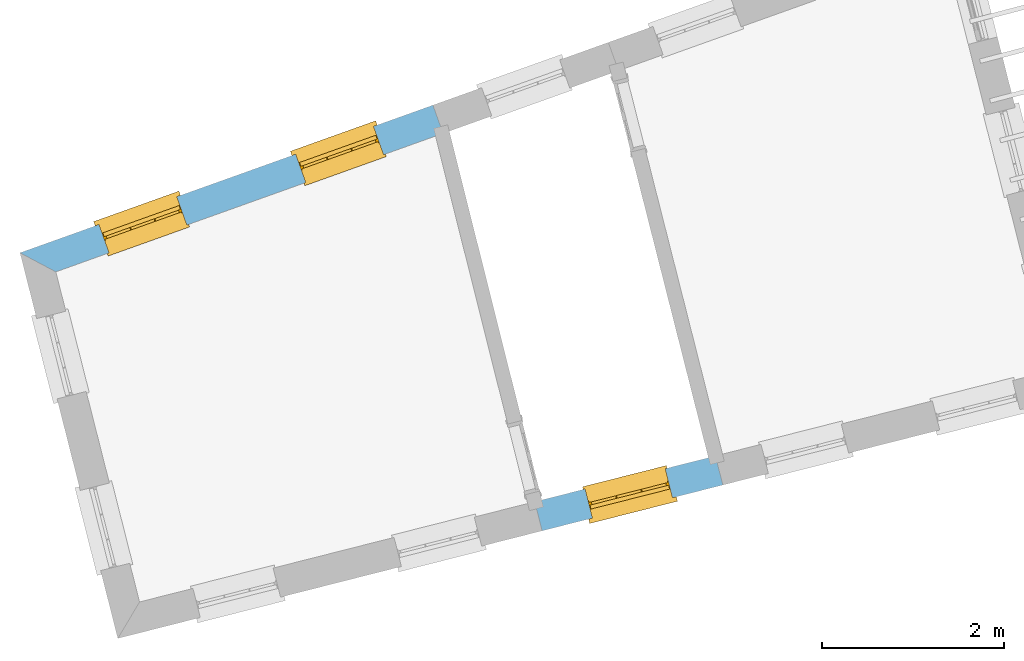
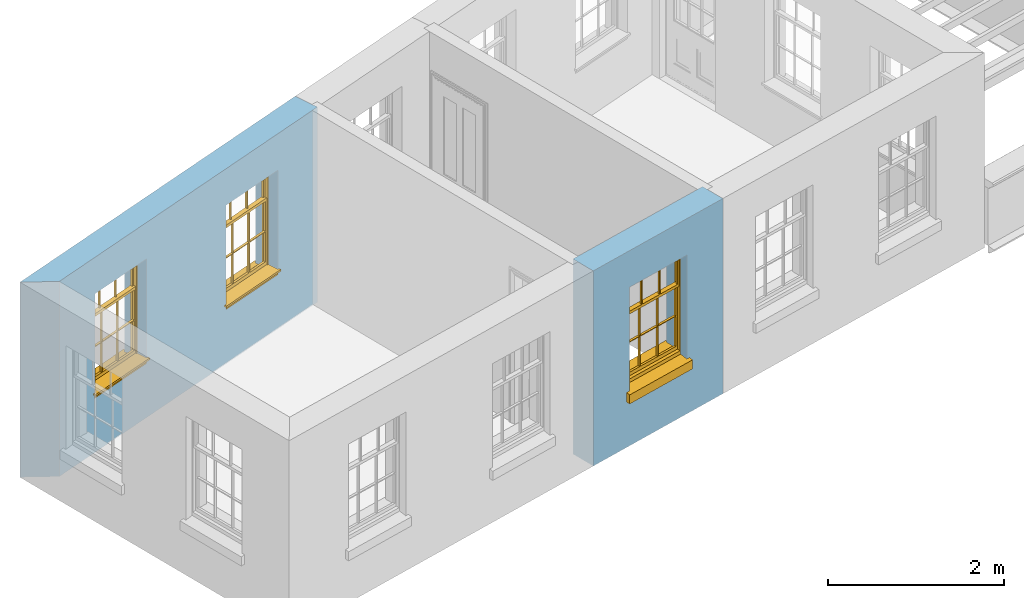
# One storey, part 4 of 10: 3 windows, 3 openings, plus 2 elements that do not belong to this part.
"""IFC2X3 building model written with IfcOpenShell, lengths in metres."""

from ifc_helpers import new_model, si_unit, frame, origin, place, context, subcontext, project, spatial, polyline, outline, extrude, faceted_brep, material, layer, layer_set, layer_usage, element, fill, save


model = new_model("IFC2X3")

# Units and contexts
model_context = context("Model", 3, world=origin())
body_context = subcontext(model_context, "Body", "Model", "MODEL_VIEW")
ifc_project = project(units=[si_unit("PLANEANGLEUNIT", "RADIAN"), si_unit("MASSUNIT", "GRAM", prefix="KILO"), si_unit("FORCEUNIT", "NEWTON", prefix="KILO"), si_unit("LENGTHUNIT", "METRE")], contexts=[model_context])

# Site, building, storey
site_placement = place(None, origin())
site = spatial("IfcSite", under=ifc_project, at=site_placement, CompositionType="ELEMENT")
building_placement = place(None, origin())
building = spatial("IfcBuilding", under=site, at=building_placement, Name="Building plot-13", CompositionType="ELEMENT")
storey_placement = place(None, frame((0.0, 0.0, 9.55)))
storey = spatial("IfcBuildingStorey", under=building, at=storey_placement, Name="Floor 2", CompositionType="ELEMENT", Elevation=9.55)

# Wall, openings, windows
ifc_material = material(Name="Masonry")
ifc_layer = layer(ifc_material, 0.33, ventilated=False)
ifc_layer_set = layer_set([ifc_layer], Name="My Wall")
ifc_layer_usage = layer_usage(ifc_layer_set, "AXIS2", "NEGATIVE", 0.08)
wall_1_placement = place(storey_placement, origin())
wall_1 = element("IfcWallStandardCase", 1, at=wall_1_placement, inside=storey, material=ifc_layer_usage, Name="exterior", context=body_context, shape_type="SweptSolid", body=[
    extrude(outline(polyline([(70.16219482777, 49.0618716141414), (70.0510857180657, 49.3726042415572), (65.5129266056267, 47.7498882014907), (65.9065629771408, 47.5401792508866), (70.16219482777, 49.0618716141414)])), origin(), (0.0, 0.0, 1.0), 2.7),
])
opening_1_placement = place(storey_placement, frame((0.0, 0.0, 0.75)))
opening_1 = element("IfcOpeningElement", 2, at=opening_1_placement, cuts=wall_1, Name="Opening", ObjectType="Opening", context=body_context, shape_type="SweptSolid", body=[
    extrude(outline(polyline([(69.3984892712811, 49.1392543973472), (68.5416205108315, 48.8328626099808), (68.6527296205358, 48.522129982565), (69.5095983809854, 48.8285217699314), (69.3984892712811, 49.1392543973472)])), origin(), (0.0, 0.0, 1.0), 1.445),
])
opening_2_placement = place(storey_placement, frame((0.0, 0.0, 0.75)))
opening_2 = element("IfcOpeningElement", 3, at=opening_2_placement, cuts=wall_1, Name="Opening", ObjectType="Opening", context=body_context, shape_type="SweptSolid", body=[
    extrude(outline(polyline([(67.2364276172623, 48.3661629215608), (66.3795588568127, 48.0597711341944), (66.490667966517, 47.7490385067786), (67.3475367269666, 48.055430294145), (67.2364276172623, 48.3661629215608)])), origin(), (0.0, 0.0, 1.0), 1.445),
])
window_1_placement = place(storey_placement, frame((69.4826628392389, 48.9038508917292, 0.75), z_axis=(0.0, 0.0, 1.0), x_axis=(-0.856868760449572, -0.306391787366422, 0.0)))
window_1 = element("IfcWindow", 4, at=window_1_placement, inside=storey, Name="bedroom outside window", OverallHeight=1.445, OverallWidth=0.91, context=body_context, shape_type="Brep", held_by="IfcProductRepresentation", body=[
    faceted_brep([(0.876875, -0.105, 0.999097), (0.876875, -0.105, 1.411875), (0.9, -0.105, 1.435), (0.033125, -0.105, 1.411875), (0.033125, -0.105, 0.999097), (0.01, -0.105, 1.435), (0.033125, -0.135, 1.411875), (0.01, -0.135, 1.435), (0.033125, -0.135, 0.999097), (0.876875, -0.135, 1.411875), (0.876875, -0.135, 0.999097), (0.9, -0.135, 1.435), (0.033125, -0.105, 0.960972), (0.01, -0.105, 0.960972), (0.033125, -0.105, 0.548195), (0.876875, -0.105, 0.960972), (0.876875, -0.105, 0.548195), (0.9, -0.105, 0.960972), (0.876875, -0.105, 0.538195), (0.876875, -0.105, 0.125417), (0.9, -0.105, 0.077167), (0.033125, -0.105, 0.125417), (0.033125, -0.105, 0.538195), (0.01, -0.105, 0.077167), (0.9, -0.135, 0.960972), (0.01, -0.135, 0.960972), (-0.0425, -0.25, 0.01), (-0.0425, -0.3, 0.001667), (0.0, -0.25, 0.01), (0.9525, -0.25, 0.01), (0.91, -0.25, 0.01), (0.9525, -0.3, 0.001667), (-0.02, 0.08, 0.077167), (0.0, 0.08, 0.077167), (-0.02, 0.11, 0.077167), (0.0, -0.06, 0.077167), (0.01, -0.06, 0.077167), (0.91, -0.06, 0.077167), (0.91, 0.08, 0.077167), (0.9, -0.06, 0.077167), (0.93, 0.08, 0.077167), (0.93, 0.11, 0.077167), (0.01, -0.105, 0.999097), (0.01, -0.075, 0.999097), (0.9, -0.105, 0.999097), (0.9, -0.075, 0.999097), (0.876875, -0.075, 0.125417), (0.876875, -0.075, 0.538195), (0.9, -0.075, 0.077167), (0.876875, -0.075, 0.548195), (0.876875, -0.075, 0.960972), (0.033125, -0.075, 0.125417), (0.01, -0.075, 0.077167), (0.033125, -0.075, 0.538195), (0.033125, -0.075, 0.960972), (0.033125, -0.075, 0.548195), (-0.02, 0.08, 0.052167), (-0.02, 0.11, 0.052167), (0.93, 0.11, 0.052167), (0.93, 0.08, 0.052167), (0.91, 0.08, 0.052167), (0.0, 0.08, 0.052167), (0.91, -0.15, 0.026667), (0.0, -0.15, 0.026667), (-0.0425, -0.3, -0.123333), (0.9525, -0.3, -0.123333), (-0.0425, -0.25, -0.123333), (0.9525, -0.25, -0.123333), (0.01, -0.06, 1.435), (0.9, -0.06, 1.435), (0.0, -0.06, 1.445), (0.91, -0.06, 1.445), (0.01, -0.15, 0.077167), (0.9, -0.15, 0.077167), (0.592292, -0.105, 0.125417), (0.592292, -0.075, 0.125417), (0.317708, -0.075, 0.125417), (0.317708, -0.105, 0.125417), (0.592292, -0.105, 0.548195), (0.317708, -0.105, 0.548195), (0.317708, -0.105, 0.538195), (0.592292, -0.105, 0.538195), (0.592292, -0.075, 0.548195), (0.317708, -0.075, 0.548195), (0.602292, -0.075, 0.548195), (0.602292, -0.105, 0.548195), (0.317708, -0.075, 0.538195), (0.307708, -0.075, 0.125417), (0.307708, -0.075, 0.538195), (0.602292, -0.075, 0.538195), (0.602292, -0.075, 0.125417), (0.592292, -0.075, 0.538195), (0.307708, -0.075, 0.548195), (0.317708, -0.075, 0.960972), (0.307708, -0.075, 0.960972), (0.602292, -0.075, 0.960972), (0.592292, -0.075, 0.960972), (0.307708, -0.105, 0.538195), (0.307708, -0.105, 0.125417), (0.307708, -0.105, 0.548195), (0.307708, -0.105, 0.960972), (0.592292, -0.105, 0.960972), (0.317708, -0.105, 0.960972), (0.602292, -0.105, 0.960972), (0.602292, -0.105, 0.538195), (0.602292, -0.105, 0.125417), (0.317708, -0.135, 1.411875), (0.307708, -0.135, 1.411875), (0.307708, -0.135, 0.999097), (0.317708, -0.135, 0.999097), (0.602292, -0.135, 1.411875), (0.592292, -0.135, 1.411875), (0.592292, -0.135, 0.999097), (0.602292, -0.135, 0.999097), (0.317708, -0.105, 0.999097), (0.307708, -0.105, 0.999097), (0.307708, -0.105, 1.411875), (0.317708, -0.105, 1.411875), (0.602292, -0.105, 0.999097), (0.592292, -0.105, 0.999097), (0.592292, -0.105, 1.411875), (0.602292, -0.105, 1.411875), (0.91, -0.15, 1.445), (0.9, -0.15, 1.435), (0.01, -0.15, 1.435), (0.0, -0.15, 1.445), (0.91, -0.25, 0.0), (0.0, -0.25, 0.0), (0.91, 0.08, 0.0), (0.0, 0.08, 0.0)], [[[0, 1, 2]], [[3, 4, 5]], [[6, 7, 8]], [[9, 10, 11]], [[12, 13, 14]], [[15, 16, 17]], [[18, 19, 20]], [[21, 22, 23]], [[24, 15, 17]], [[13, 12, 25]], [[26, 27, 28]], [[29, 30, 31]], [[32, 33, 34]], [[35, 36, 33]], [[37, 38, 39]], [[40, 41, 38]], [[42, 4, 43]], [[44, 45, 0]], [[46, 47, 48]], [[49, 50, 45]], [[51, 52, 53]], [[54, 55, 43]], [[38, 33, 36, 39]], [[41, 34, 33, 38]], [[56, 32, 34, 57]], [[57, 34, 41, 58]], [[58, 41, 40, 59]], [[57, 58, 60, 61]], [[52, 48, 39, 36]], [[62, 63, 28, 30]], [[27, 31, 30, 28]], [[27, 64, 65, 31]], [[66, 67, 65, 64]], [[2, 5, 68, 69]], [[68, 70, 71, 69]], [[20, 23, 72, 73]], [[73, 72, 63, 62]], [[74, 75, 76, 77]], [[78, 79, 80, 81]], [[78, 82, 83, 79]], [[16, 49, 84, 85]], [[86, 76, 87, 88]], [[89, 90, 75, 91]], [[92, 88, 53, 55]], [[82, 91, 86, 83]], [[93, 83, 92, 94]], [[95, 84, 82, 96]], [[89, 84, 49, 47]], [[97, 88, 87, 98]], [[22, 53, 88, 97]], [[81, 91, 75, 74]], [[80, 86, 91, 81]], [[77, 76, 86, 80]], [[99, 92, 55, 14]], [[100, 94, 92, 99]], [[101, 96, 82, 78]], [[79, 83, 93, 102]], [[85, 84, 95, 103]], [[104, 89, 47, 18]], [[105, 90, 89, 104]], [[104, 18, 16, 85]], [[80, 97, 98, 77]], [[104, 81, 74, 105]], [[103, 101, 78, 85]], [[99, 14, 22, 97]], [[102, 100, 99, 79]], [[106, 107, 108, 109]], [[110, 111, 112, 113]], [[114, 115, 116, 117]], [[118, 119, 120, 121]], [[107, 116, 115, 108]], [[111, 120, 119, 112]], [[109, 114, 117, 106]], [[113, 118, 121, 110]], [[85, 78, 81, 104]], [[84, 89, 91, 82]], [[83, 86, 88, 92]], [[79, 99, 97, 80]], [[109, 112, 119, 114]], [[102, 93, 96, 101]], [[106, 117, 120, 111]], [[98, 87, 51, 21]], [[6, 3, 116, 107]], [[110, 121, 1, 9]], [[19, 46, 90, 105]], [[26, 66, 64, 27]], [[29, 31, 65, 67]], [[25, 24, 112, 109]], [[11, 7, 106, 111]], [[75, 48, 52, 76]], [[43, 45, 96, 93]], [[45, 43, 114, 119]], [[5, 2, 120, 117]], [[24, 25, 102, 101]], [[42, 5, 4]], [[2, 44, 0]], [[49, 45, 48, 47]], [[52, 43, 55, 53]], [[14, 13, 23, 22]], [[20, 17, 16, 18]], [[24, 11, 10]], [[25, 8, 7]], [[8, 4, 3, 6]], [[9, 1, 0, 10]], [[15, 50, 49, 16]], [[18, 47, 46, 19]], [[21, 51, 53, 22]], [[14, 55, 54, 12]], [[44, 2, 69, 45]], [[68, 5, 42, 43]], [[36, 35, 70, 68]], [[39, 69, 71, 37]], [[62, 122, 123, 73]], [[63, 72, 124, 125]], [[8, 108, 115, 4]], [[113, 10, 0, 118]], [[94, 100, 12, 54]], [[17, 20, 73, 24]], [[72, 23, 13, 25]], [[52, 36, 68, 43]], [[69, 39, 48, 45]], [[11, 24, 73, 123]], [[7, 124, 72, 25]], [[23, 77, 98]], [[98, 21, 23]], [[105, 74, 20]], [[20, 19, 105]], [[20, 74, 77, 23]], [[113, 112, 24]], [[24, 10, 113]], [[25, 109, 108]], [[108, 8, 25]], [[110, 9, 11]], [[11, 111, 110]], [[7, 6, 107]], [[107, 106, 7]], [[5, 117, 116]], [[116, 3, 5]], [[121, 120, 2]], [[2, 1, 121]], [[11, 123, 124, 7]], [[122, 125, 124, 123]], [[43, 93, 94]], [[94, 54, 43]], [[96, 45, 95]], [[50, 95, 45]], [[15, 103, 95, 50]], [[48, 75, 90]], [[90, 46, 48]], [[87, 76, 52]], [[52, 51, 87]], [[103, 15, 24]], [[24, 101, 103]], [[100, 102, 25]], [[25, 12, 100]], [[115, 114, 43]], [[43, 4, 115]], [[118, 0, 45]], [[45, 119, 118]], [[71, 70, 125, 122]], [[70, 35, 63, 125]], [[122, 62, 37, 71]], [[126, 67, 66, 127]], [[60, 58, 59]], [[38, 60, 59, 40]], [[61, 56, 57]], [[32, 56, 61, 33]], [[61, 60, 128, 129]], [[62, 60, 38, 37]], [[126, 128, 60, 62]], [[33, 61, 63, 35]], [[61, 129, 127, 63]], [[128, 126, 127, 129]], [[28, 127, 66, 26]], [[63, 127, 28]], [[29, 67, 126, 30]], [[30, 126, 62]]]),
])
fill(opening_1, window_1)
window_2_placement = place(storey_placement, frame((67.3206011852201, 48.1307594159428, 0.75), z_axis=(0.0, 0.0, 1.0), x_axis=(-0.856868760449572, -0.306391787366422, 0.0)))
window_2 = element("IfcWindow", 5, at=window_2_placement, inside=storey, Name="bedroom outside window", OverallHeight=1.445, OverallWidth=0.91, context=body_context, shape_type="Brep", held_by="IfcProductRepresentation", body=[
    faceted_brep([(0.876875, -0.105, 0.999097), (0.876875, -0.105, 1.411875), (0.9, -0.105, 1.435), (0.033125, -0.105, 1.411875), (0.033125, -0.105, 0.999097), (0.01, -0.105, 1.435), (0.033125, -0.135, 1.411875), (0.01, -0.135, 1.435), (0.033125, -0.135, 0.999097), (0.876875, -0.135, 1.411875), (0.876875, -0.135, 0.999097), (0.9, -0.135, 1.435), (0.033125, -0.105, 0.960972), (0.01, -0.105, 0.960972), (0.033125, -0.105, 0.548195), (0.876875, -0.105, 0.960972), (0.876875, -0.105, 0.548195), (0.9, -0.105, 0.960972), (0.876875, -0.105, 0.538195), (0.876875, -0.105, 0.125417), (0.9, -0.105, 0.077167), (0.033125, -0.105, 0.125417), (0.033125, -0.105, 0.538195), (0.01, -0.105, 0.077167), (0.9, -0.135, 0.960972), (0.01, -0.135, 0.960972), (-0.0425, -0.25, 0.01), (-0.0425, -0.3, 0.001667), (0.0, -0.25, 0.01), (0.9525, -0.25, 0.01), (0.91, -0.25, 0.01), (0.9525, -0.3, 0.001667), (-0.02, 0.08, 0.077167), (0.0, 0.08, 0.077167), (-0.02, 0.11, 0.077167), (0.0, -0.06, 0.077167), (0.01, -0.06, 0.077167), (0.91, -0.06, 0.077167), (0.91, 0.08, 0.077167), (0.9, -0.06, 0.077167), (0.93, 0.08, 0.077167), (0.93, 0.11, 0.077167), (0.01, -0.105, 0.999097), (0.01, -0.075, 0.999097), (0.9, -0.105, 0.999097), (0.9, -0.075, 0.999097), (0.876875, -0.075, 0.125417), (0.876875, -0.075, 0.538195), (0.9, -0.075, 0.077167), (0.876875, -0.075, 0.548195), (0.876875, -0.075, 0.960972), (0.033125, -0.075, 0.125417), (0.01, -0.075, 0.077167), (0.033125, -0.075, 0.538195), (0.033125, -0.075, 0.960972), (0.033125, -0.075, 0.548195), (-0.02, 0.08, 0.052167), (-0.02, 0.11, 0.052167), (0.93, 0.11, 0.052167), (0.93, 0.08, 0.052167), (0.91, 0.08, 0.052167), (0.0, 0.08, 0.052167), (0.91, -0.15, 0.026667), (0.0, -0.15, 0.026667), (-0.0425, -0.3, -0.123333), (0.9525, -0.3, -0.123333), (-0.0425, -0.25, -0.123333), (0.9525, -0.25, -0.123333), (0.01, -0.06, 1.435), (0.9, -0.06, 1.435), (0.0, -0.06, 1.445), (0.91, -0.06, 1.445), (0.01, -0.15, 0.077167), (0.9, -0.15, 0.077167), (0.592292, -0.105, 0.125417), (0.592292, -0.075, 0.125417), (0.317708, -0.075, 0.125417), (0.317708, -0.105, 0.125417), (0.592292, -0.105, 0.548195), (0.317708, -0.105, 0.548195), (0.317708, -0.105, 0.538195), (0.592292, -0.105, 0.538195), (0.592292, -0.075, 0.548195), (0.317708, -0.075, 0.548195), (0.602292, -0.075, 0.548195), (0.602292, -0.105, 0.548195), (0.317708, -0.075, 0.538195), (0.307708, -0.075, 0.125417), (0.307708, -0.075, 0.538195), (0.602292, -0.075, 0.538195), (0.602292, -0.075, 0.125417), (0.592292, -0.075, 0.538195), (0.307708, -0.075, 0.548195), (0.317708, -0.075, 0.960972), (0.307708, -0.075, 0.960972), (0.602292, -0.075, 0.960972), (0.592292, -0.075, 0.960972), (0.307708, -0.105, 0.538195), (0.307708, -0.105, 0.125417), (0.307708, -0.105, 0.548195), (0.307708, -0.105, 0.960972), (0.592292, -0.105, 0.960972), (0.317708, -0.105, 0.960972), (0.602292, -0.105, 0.960972), (0.602292, -0.105, 0.538195), (0.602292, -0.105, 0.125417), (0.317708, -0.135, 1.411875), (0.307708, -0.135, 1.411875), (0.307708, -0.135, 0.999097), (0.317708, -0.135, 0.999097), (0.602292, -0.135, 1.411875), (0.592292, -0.135, 1.411875), (0.592292, -0.135, 0.999097), (0.602292, -0.135, 0.999097), (0.317708, -0.105, 0.999097), (0.307708, -0.105, 0.999097), (0.307708, -0.105, 1.411875), (0.317708, -0.105, 1.411875), (0.602292, -0.105, 0.999097), (0.592292, -0.105, 0.999097), (0.592292, -0.105, 1.411875), (0.602292, -0.105, 1.411875), (0.91, -0.15, 1.445), (0.9, -0.15, 1.435), (0.01, -0.15, 1.435), (0.0, -0.15, 1.445), (0.91, -0.25, 0.0), (0.0, -0.25, 0.0), (0.91, 0.08, 0.0), (0.0, 0.08, 0.0)], [[[0, 1, 2]], [[3, 4, 5]], [[6, 7, 8]], [[9, 10, 11]], [[12, 13, 14]], [[15, 16, 17]], [[18, 19, 20]], [[21, 22, 23]], [[24, 15, 17]], [[13, 12, 25]], [[26, 27, 28]], [[29, 30, 31]], [[32, 33, 34]], [[35, 36, 33]], [[37, 38, 39]], [[40, 41, 38]], [[42, 4, 43]], [[44, 45, 0]], [[46, 47, 48]], [[49, 50, 45]], [[51, 52, 53]], [[54, 55, 43]], [[38, 33, 36, 39]], [[41, 34, 33, 38]], [[56, 32, 34, 57]], [[57, 34, 41, 58]], [[58, 41, 40, 59]], [[57, 58, 60, 61]], [[52, 48, 39, 36]], [[62, 63, 28, 30]], [[27, 31, 30, 28]], [[27, 64, 65, 31]], [[66, 67, 65, 64]], [[2, 5, 68, 69]], [[68, 70, 71, 69]], [[20, 23, 72, 73]], [[73, 72, 63, 62]], [[74, 75, 76, 77]], [[78, 79, 80, 81]], [[78, 82, 83, 79]], [[16, 49, 84, 85]], [[86, 76, 87, 88]], [[89, 90, 75, 91]], [[92, 88, 53, 55]], [[82, 91, 86, 83]], [[93, 83, 92, 94]], [[95, 84, 82, 96]], [[89, 84, 49, 47]], [[97, 88, 87, 98]], [[22, 53, 88, 97]], [[81, 91, 75, 74]], [[80, 86, 91, 81]], [[77, 76, 86, 80]], [[99, 92, 55, 14]], [[100, 94, 92, 99]], [[101, 96, 82, 78]], [[79, 83, 93, 102]], [[85, 84, 95, 103]], [[104, 89, 47, 18]], [[105, 90, 89, 104]], [[104, 18, 16, 85]], [[80, 97, 98, 77]], [[104, 81, 74, 105]], [[103, 101, 78, 85]], [[99, 14, 22, 97]], [[102, 100, 99, 79]], [[106, 107, 108, 109]], [[110, 111, 112, 113]], [[114, 115, 116, 117]], [[118, 119, 120, 121]], [[107, 116, 115, 108]], [[111, 120, 119, 112]], [[109, 114, 117, 106]], [[113, 118, 121, 110]], [[85, 78, 81, 104]], [[84, 89, 91, 82]], [[83, 86, 88, 92]], [[79, 99, 97, 80]], [[109, 112, 119, 114]], [[102, 93, 96, 101]], [[106, 117, 120, 111]], [[98, 87, 51, 21]], [[6, 3, 116, 107]], [[110, 121, 1, 9]], [[19, 46, 90, 105]], [[26, 66, 64, 27]], [[29, 31, 65, 67]], [[25, 24, 112, 109]], [[11, 7, 106, 111]], [[75, 48, 52, 76]], [[43, 45, 96, 93]], [[45, 43, 114, 119]], [[5, 2, 120, 117]], [[24, 25, 102, 101]], [[42, 5, 4]], [[2, 44, 0]], [[49, 45, 48, 47]], [[52, 43, 55, 53]], [[14, 13, 23, 22]], [[20, 17, 16, 18]], [[24, 11, 10]], [[25, 8, 7]], [[8, 4, 3, 6]], [[9, 1, 0, 10]], [[15, 50, 49, 16]], [[18, 47, 46, 19]], [[21, 51, 53, 22]], [[14, 55, 54, 12]], [[44, 2, 69, 45]], [[68, 5, 42, 43]], [[36, 35, 70, 68]], [[39, 69, 71, 37]], [[62, 122, 123, 73]], [[63, 72, 124, 125]], [[8, 108, 115, 4]], [[113, 10, 0, 118]], [[94, 100, 12, 54]], [[17, 20, 73, 24]], [[72, 23, 13, 25]], [[52, 36, 68, 43]], [[69, 39, 48, 45]], [[11, 24, 73, 123]], [[7, 124, 72, 25]], [[23, 77, 98]], [[98, 21, 23]], [[105, 74, 20]], [[20, 19, 105]], [[20, 74, 77, 23]], [[113, 112, 24]], [[24, 10, 113]], [[25, 109, 108]], [[108, 8, 25]], [[110, 9, 11]], [[11, 111, 110]], [[7, 6, 107]], [[107, 106, 7]], [[5, 117, 116]], [[116, 3, 5]], [[121, 120, 2]], [[2, 1, 121]], [[11, 123, 124, 7]], [[122, 125, 124, 123]], [[43, 93, 94]], [[94, 54, 43]], [[96, 45, 95]], [[50, 95, 45]], [[15, 103, 95, 50]], [[48, 75, 90]], [[90, 46, 48]], [[87, 76, 52]], [[52, 51, 87]], [[103, 15, 24]], [[24, 101, 103]], [[100, 102, 25]], [[25, 12, 100]], [[115, 114, 43]], [[43, 4, 115]], [[118, 0, 45]], [[45, 119, 118]], [[71, 70, 125, 122]], [[70, 35, 63, 125]], [[122, 62, 37, 71]], [[126, 67, 66, 127]], [[60, 58, 59]], [[38, 60, 59, 40]], [[61, 56, 57]], [[32, 56, 61, 33]], [[61, 60, 128, 129]], [[62, 60, 38, 37]], [[126, 128, 60, 62]], [[33, 61, 63, 35]], [[61, 129, 127, 63]], [[128, 126, 127, 129]], [[28, 127, 66, 26]], [[63, 127, 28]], [[29, 67, 126, 30]], [[30, 126, 62]]]),
])
fill(opening_2, window_2)

# Wall, opening, window
wall_2_placement = place(storey_placement, origin())
wall_2 = element("IfcWallStandardCase", 6, at=wall_2_placement, inside=storey, material=ifc_layer_usage, Name="exterior", context=body_context, shape_type="SweptSolid", body=[
    extrude(outline(polyline([(71.1697724625834, 45.0137628318924), (71.2509007169492, 44.6938906600119), (73.2374229095042, 45.1977265416814), (73.1562946551384, 45.5175987135619), (71.1697724625834, 45.0137628318924)])), origin(), (0.0, 0.0, 1.0), 2.7),
])
opening_3_placement = place(storey_placement, frame((0.0, 0.0, 0.75)))
opening_3 = element("IfcOpeningElement", 7, at=opening_3_placement, cuts=wall_2, Name="Opening", ObjectType="Opening", context=body_context, shape_type="SweptSolid", body=[
    extrude(outline(polyline([(71.8031259398763, 44.8339499470999), (72.6851976865771, 45.0576672545935), (72.6040694322113, 45.377539426474), (71.7219976855105, 45.1538221189804), (71.8031259398763, 44.8339499470999)])), origin(), (0.0, 0.0, 1.0), 1.445),
])
window_3_placement = place(storey_placement, frame((71.7416651411143, 45.0762773500396, 0.75), z_axis=(0.0, 0.0, 1.0), x_axis=(0.882071746700788, 0.223717307493636, 0.0)))
window_3 = element("IfcWindow", 8, at=window_3_placement, inside=storey, Name="circulation outside window", OverallHeight=1.445, OverallWidth=0.91, context=body_context, shape_type="Brep", held_by="IfcProductRepresentation", body=[
    faceted_brep([(0.876875, -0.105, 0.999097), (0.876875, -0.105, 1.411875), (0.9, -0.105, 1.435), (0.033125, -0.105, 1.411875), (0.033125, -0.105, 0.999097), (0.01, -0.105, 1.435), (0.033125, -0.135, 1.411875), (0.01, -0.135, 1.435), (0.033125, -0.135, 0.999097), (0.876875, -0.135, 1.411875), (0.876875, -0.135, 0.999097), (0.9, -0.135, 1.435), (0.033125, -0.105, 0.960972), (0.01, -0.105, 0.960972), (0.033125, -0.105, 0.548195), (0.876875, -0.105, 0.960972), (0.876875, -0.105, 0.548195), (0.9, -0.105, 0.960972), (0.876875, -0.105, 0.538195), (0.876875, -0.105, 0.125417), (0.9, -0.105, 0.077167), (0.033125, -0.105, 0.125417), (0.033125, -0.105, 0.538195), (0.01, -0.105, 0.077167), (0.9, -0.135, 0.960972), (0.01, -0.135, 0.960972), (-0.0425, -0.25, 0.01), (-0.0425, -0.3, 0.001667), (0.0, -0.25, 0.01), (0.9525, -0.25, 0.01), (0.91, -0.25, 0.01), (0.9525, -0.3, 0.001667), (-0.02, 0.08, 0.077167), (0.0, 0.08, 0.077167), (-0.02, 0.11, 0.077167), (0.0, -0.06, 0.077167), (0.01, -0.06, 0.077167), (0.91, -0.06, 0.077167), (0.91, 0.08, 0.077167), (0.9, -0.06, 0.077167), (0.93, 0.08, 0.077167), (0.93, 0.11, 0.077167), (0.01, -0.105, 0.999097), (0.01, -0.075, 0.999097), (0.9, -0.105, 0.999097), (0.9, -0.075, 0.999097), (0.876875, -0.075, 0.125417), (0.876875, -0.075, 0.538195), (0.9, -0.075, 0.077167), (0.876875, -0.075, 0.548195), (0.876875, -0.075, 0.960972), (0.033125, -0.075, 0.125417), (0.01, -0.075, 0.077167), (0.033125, -0.075, 0.538195), (0.033125, -0.075, 0.960972), (0.033125, -0.075, 0.548195), (-0.02, 0.08, 0.052167), (-0.02, 0.11, 0.052167), (0.93, 0.11, 0.052167), (0.93, 0.08, 0.052167), (0.91, 0.08, 0.052167), (0.0, 0.08, 0.052167), (0.91, -0.15, 0.026667), (0.0, -0.15, 0.026667), (-0.0425, -0.3, -0.123333), (0.9525, -0.3, -0.123333), (-0.0425, -0.25, -0.123333), (0.9525, -0.25, -0.123333), (0.01, -0.06, 1.435), (0.9, -0.06, 1.435), (0.0, -0.06, 1.445), (0.91, -0.06, 1.445), (0.01, -0.15, 0.077167), (0.9, -0.15, 0.077167), (0.592292, -0.105, 0.125417), (0.592292, -0.075, 0.125417), (0.317708, -0.075, 0.125417), (0.317708, -0.105, 0.125417), (0.592292, -0.105, 0.548195), (0.317708, -0.105, 0.548195), (0.317708, -0.105, 0.538195), (0.592292, -0.105, 0.538195), (0.592292, -0.075, 0.548195), (0.317708, -0.075, 0.548195), (0.602292, -0.075, 0.548195), (0.602292, -0.105, 0.548195), (0.317708, -0.075, 0.538195), (0.307708, -0.075, 0.125417), (0.307708, -0.075, 0.538195), (0.602292, -0.075, 0.538195), (0.602292, -0.075, 0.125417), (0.592292, -0.075, 0.538195), (0.307708, -0.075, 0.548195), (0.317708, -0.075, 0.960972), (0.307708, -0.075, 0.960972), (0.602292, -0.075, 0.960972), (0.592292, -0.075, 0.960972), (0.307708, -0.105, 0.538195), (0.307708, -0.105, 0.125417), (0.307708, -0.105, 0.548195), (0.307708, -0.105, 0.960972), (0.592292, -0.105, 0.960972), (0.317708, -0.105, 0.960972), (0.602292, -0.105, 0.960972), (0.602292, -0.105, 0.538195), (0.602292, -0.105, 0.125417), (0.317708, -0.135, 1.411875), (0.307708, -0.135, 1.411875), (0.307708, -0.135, 0.999097), (0.317708, -0.135, 0.999097), (0.602292, -0.135, 1.411875), (0.592292, -0.135, 1.411875), (0.592292, -0.135, 0.999097), (0.602292, -0.135, 0.999097), (0.317708, -0.105, 0.999097), (0.307708, -0.105, 0.999097), (0.307708, -0.105, 1.411875), (0.317708, -0.105, 1.411875), (0.602292, -0.105, 0.999097), (0.592292, -0.105, 0.999097), (0.592292, -0.105, 1.411875), (0.602292, -0.105, 1.411875), (0.91, -0.15, 1.445), (0.9, -0.15, 1.435), (0.01, -0.15, 1.435), (0.0, -0.15, 1.445), (0.91, -0.25, 0.0), (0.0, -0.25, 0.0), (0.91, 0.08, 0.0), (0.0, 0.08, 0.0)], [[[0, 1, 2]], [[3, 4, 5]], [[6, 7, 8]], [[9, 10, 11]], [[12, 13, 14]], [[15, 16, 17]], [[18, 19, 20]], [[21, 22, 23]], [[24, 15, 17]], [[13, 12, 25]], [[26, 27, 28]], [[29, 30, 31]], [[32, 33, 34]], [[35, 36, 33]], [[37, 38, 39]], [[40, 41, 38]], [[42, 4, 43]], [[44, 45, 0]], [[46, 47, 48]], [[49, 50, 45]], [[51, 52, 53]], [[54, 55, 43]], [[38, 33, 36, 39]], [[41, 34, 33, 38]], [[56, 32, 34, 57]], [[57, 34, 41, 58]], [[58, 41, 40, 59]], [[57, 58, 60, 61]], [[52, 48, 39, 36]], [[62, 63, 28, 30]], [[27, 31, 30, 28]], [[27, 64, 65, 31]], [[66, 67, 65, 64]], [[2, 5, 68, 69]], [[68, 70, 71, 69]], [[20, 23, 72, 73]], [[73, 72, 63, 62]], [[74, 75, 76, 77]], [[78, 79, 80, 81]], [[78, 82, 83, 79]], [[16, 49, 84, 85]], [[86, 76, 87, 88]], [[89, 90, 75, 91]], [[92, 88, 53, 55]], [[82, 91, 86, 83]], [[93, 83, 92, 94]], [[95, 84, 82, 96]], [[89, 84, 49, 47]], [[97, 88, 87, 98]], [[22, 53, 88, 97]], [[81, 91, 75, 74]], [[80, 86, 91, 81]], [[77, 76, 86, 80]], [[99, 92, 55, 14]], [[100, 94, 92, 99]], [[101, 96, 82, 78]], [[79, 83, 93, 102]], [[85, 84, 95, 103]], [[104, 89, 47, 18]], [[105, 90, 89, 104]], [[104, 18, 16, 85]], [[80, 97, 98, 77]], [[104, 81, 74, 105]], [[103, 101, 78, 85]], [[99, 14, 22, 97]], [[102, 100, 99, 79]], [[106, 107, 108, 109]], [[110, 111, 112, 113]], [[114, 115, 116, 117]], [[118, 119, 120, 121]], [[107, 116, 115, 108]], [[111, 120, 119, 112]], [[109, 114, 117, 106]], [[113, 118, 121, 110]], [[85, 78, 81, 104]], [[84, 89, 91, 82]], [[83, 86, 88, 92]], [[79, 99, 97, 80]], [[109, 112, 119, 114]], [[102, 93, 96, 101]], [[106, 117, 120, 111]], [[98, 87, 51, 21]], [[6, 3, 116, 107]], [[110, 121, 1, 9]], [[19, 46, 90, 105]], [[26, 66, 64, 27]], [[29, 31, 65, 67]], [[25, 24, 112, 109]], [[11, 7, 106, 111]], [[75, 48, 52, 76]], [[43, 45, 96, 93]], [[45, 43, 114, 119]], [[5, 2, 120, 117]], [[24, 25, 102, 101]], [[42, 5, 4]], [[2, 44, 0]], [[49, 45, 48, 47]], [[52, 43, 55, 53]], [[14, 13, 23, 22]], [[20, 17, 16, 18]], [[24, 11, 10]], [[25, 8, 7]], [[8, 4, 3, 6]], [[9, 1, 0, 10]], [[15, 50, 49, 16]], [[18, 47, 46, 19]], [[21, 51, 53, 22]], [[14, 55, 54, 12]], [[44, 2, 69, 45]], [[68, 5, 42, 43]], [[36, 35, 70, 68]], [[39, 69, 71, 37]], [[62, 122, 123, 73]], [[63, 72, 124, 125]], [[8, 108, 115, 4]], [[113, 10, 0, 118]], [[94, 100, 12, 54]], [[17, 20, 73, 24]], [[72, 23, 13, 25]], [[52, 36, 68, 43]], [[69, 39, 48, 45]], [[11, 24, 73, 123]], [[7, 124, 72, 25]], [[23, 77, 98]], [[98, 21, 23]], [[105, 74, 20]], [[20, 19, 105]], [[20, 74, 77, 23]], [[113, 112, 24]], [[24, 10, 113]], [[25, 109, 108]], [[108, 8, 25]], [[110, 9, 11]], [[11, 111, 110]], [[7, 6, 107]], [[107, 106, 7]], [[5, 117, 116]], [[116, 3, 5]], [[121, 120, 2]], [[2, 1, 121]], [[11, 123, 124, 7]], [[122, 125, 124, 123]], [[43, 93, 94]], [[94, 54, 43]], [[96, 45, 95]], [[50, 95, 45]], [[15, 103, 95, 50]], [[48, 75, 90]], [[90, 46, 48]], [[87, 76, 52]], [[52, 51, 87]], [[103, 15, 24]], [[24, 101, 103]], [[100, 102, 25]], [[25, 12, 100]], [[115, 114, 43]], [[43, 4, 115]], [[118, 0, 45]], [[45, 119, 118]], [[71, 70, 125, 122]], [[70, 35, 63, 125]], [[122, 62, 37, 71]], [[126, 67, 66, 127]], [[60, 58, 59]], [[38, 60, 59, 40]], [[61, 56, 57]], [[32, 56, 61, 33]], [[61, 60, 128, 129]], [[62, 60, 38, 37]], [[126, 128, 60, 62]], [[33, 61, 63, 35]], [[61, 129, 127, 63]], [[128, 126, 127, 129]], [[28, 127, 66, 26]], [[63, 127, 28]], [[29, 67, 126, 30]], [[30, 126, 62]]]),
])
fill(opening_3, window_3)

save(model, "model.ifc")
